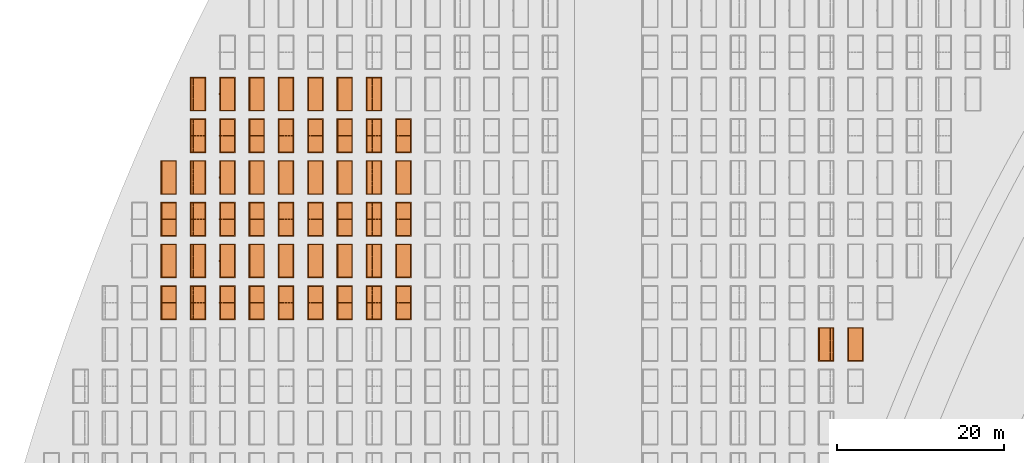
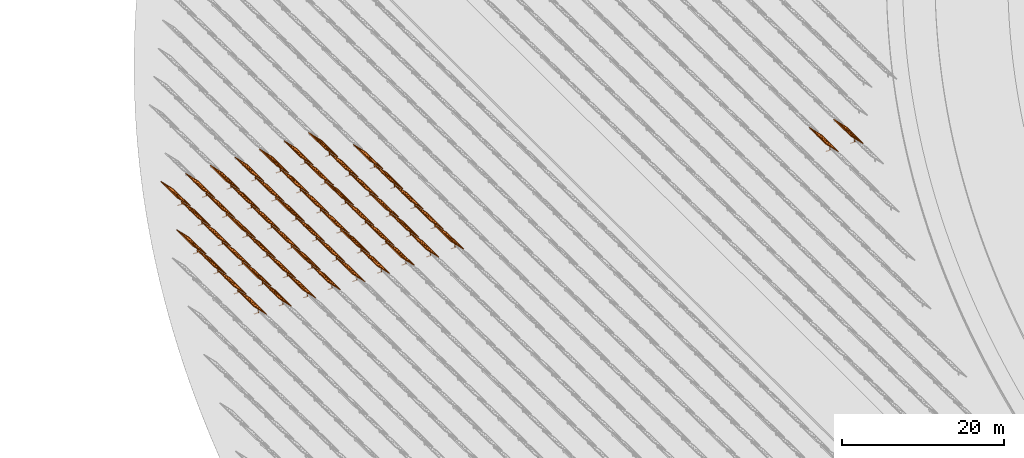
# One storey, part 27 of 39: 53 proxies.
"""IFC2X3 building model written with IfcOpenShell, lengths in millimetres."""

from ifc_helpers import new_model, entity, si_unit, converted_unit, derived_unit, direction, frame, frame_2d, origin, origin_2d_with_axis, place, context, subcontext, project, spatial, polyline, rectangle, outline, extrude, source, transform, mapped, material, material_list, element, save


model = new_model("IFC2X3")

# Units and contexts
model_context = context("Model", 3, precision=1e-06, world=origin(), true_north=direction((2.0, 6.12303176911189e-17, 1.0)))
context_of_model = context(None, 3, precision=1e-06, world=origin(), true_north=direction((2.0, 6.12303176911189e-17, 1.0)))
body_context = subcontext(model_context, "Body", "Model", "MODEL_VIEW")
ifc_project = project(units=[si_unit("LENGTHUNIT", "METRE", prefix="MILLI"), si_unit("AREAUNIT", "SQUARE_METRE", prefix="MILLI"), si_unit("VOLUMEUNIT", "CUBIC_METRE", prefix="MILLI"), converted_unit("PLANEANGLEUNIT", "DEGREE", entity("IfcRatioMeasure", 0.0174532925199433), si_unit("PLANEANGLEUNIT", "RADIAN"), dimensions=[0, 0, 0, 0, 0, 0, 0]), si_unit("MASSUNIT", "GRAM", prefix="KILO"), si_unit("TIMEUNIT", "SECOND"), si_unit("THERMODYNAMICTEMPERATUREUNIT", "KELVIN"), derived_unit("THERMALTRANSMITTANCEUNIT", [(si_unit("MASSUNIT", "GRAM", prefix="KILO"), 1), (si_unit("THERMODYNAMICTEMPERATUREUNIT", "KELVIN"), -1), (si_unit("TIMEUNIT", "SECOND"), -3)]), derived_unit("VOLUMETRICFLOWRATEUNIT", [(si_unit("LENGTHUNIT", "METRE"), 3), (si_unit("TIMEUNIT", "SECOND"), -1)])], contexts=[model_context, context_of_model])

# Site, building, storey
site_placement = place(None, origin())
site = spatial("IfcSite", under=ifc_project, at=site_placement, CompositionType="ELEMENT")
building_placement = place(site_placement, origin())
building = spatial("IfcBuilding", under=site, at=building_placement, CompositionType="ELEMENT")
storey_placement = place(building_placement, frame((0.0, 0.0, 4000.0)))
storey = spatial("IfcBuildingStorey", under=building, at=storey_placement, Name="Level 2", CompositionType="ELEMENT", Elevation=4000.0)

# Proxies
ifc_material_1 = material(Name="Stand-Steel")
ifc_material_2 = material(Name="Aluminium")
ifc_material_3 = material(Name="Glass")
ifc_material_list_1 = material_list([ifc_material_1, ifc_material_2, ifc_material_3])
shared_shape = source(origin(), body_context, "Body", "SweptSolid", [
    extrude(outline(polyline([(-629.526235435404, -220.0), (329.763117717702, -220.0), (329.763117717703, 410.0), (299.763117717703, 410.0), (299.763117717702, -190.0), (-629.526235435404, -190.0), (-629.526235435404, -220.0)])), frame((-190.00003127179, -100.0, 299.763117717707), z_axis=(0.0, 1.0, 0.0), x_axis=(0.0, 0.0, -1.0)), (0.0, 0.0, 1.0), 200.0),
    extrude(rectangle(XDim=20.0000000000001, YDim=200.0, at=frame_2d((0.0, -7.105427357601e-14), x_axis=(0.0, 1.0))), frame((-7.07109908365613, 0.0, 922.21828534124), z_axis=(-0.70710678118654, 0.0, 0.707106781186555), x_axis=(0.0, 1.0, 0.0)), (0.0, 0.0, 1.0), 2600.0),
    extrude(rectangle(XDim=24.9999999999997, YDim=24.9999999999999, at=frame_2d((2.87769807982841e-13, -9.50350909079134e-14), x_axis=(1.0, 0.0))), frame((-1449.56292018118, -1950.0, 2449.57494522722), z_axis=(0.0, 1.0, 0.0), x_axis=(-0.707106781186548, 0.0, -0.707106781186548)), (0.0, 0.0, 1.0), 3900.0),
    extrude(rectangle(XDim=24.9999999999999, YDim=25.0000000000001, at=origin_2d_with_axis()), frame((-1096.0095295879, -1950.0, 2096.02155463395), z_axis=(0.0, 1.0, 0.0), x_axis=(-0.707106781186542, 0.0, -0.707106781186553)), (0.0, 0.0, 1.0), 3900.0),
    extrude(rectangle(XDim=24.9999999999999, YDim=25.0000000000001, at=origin_2d_with_axis()), frame((-742.456138994631, -1950.0, 1742.46816404067), z_axis=(0.0, 1.0, 0.0), x_axis=(-0.707106781186542, 0.0, -0.707106781186553)), (0.0, 0.0, 1.0), 3900.0),
    extrude(rectangle(XDim=25.0, YDim=24.9999999999997, at=frame_2d((-7.19424519957101e-14, 1.19904086659517e-13), x_axis=(1.0, 0.0))), frame((-388.902748401358, -1950.0, 1388.9147734474), z_axis=(0.0, 1.0, 0.0), x_axis=(-0.707106781186545, 0.0, -0.70710678118655)), (0.0, 0.0, 1.0), 3900.0),
    extrude(rectangle(XDim=25.0000000000002, YDim=25.0, at=frame_2d((1.35891298214119e-13, 6.21724893790088e-15), x_axis=(0.0, 1.0))), frame((-35.3553703311048, 1500.0, 1035.35537033109), z_axis=(-0.707106781186544, 0.0, 0.707106781186551), x_axis=(0.0, 1.0, 0.0)), (0.0, 0.0, 1.0), 2440.0),
    extrude(rectangle(XDim=25.0000000000002, YDim=25.0, at=frame_2d((0.0, 1.77635683940025e-15), x_axis=(0.0, 1.0))), frame((-35.3553703311059, 1000.0, 1035.35537033109), z_axis=(-0.707106781186546, 0.0, 0.707106781186549), x_axis=(0.0, 1.0, 0.0)), (0.0, 0.0, 1.0), 2440.0),
    extrude(rectangle(XDim=25.0000000000002, YDim=25.0, at=frame_2d((0.0, 8.43769498715119e-14), x_axis=(0.0, 1.0))), frame((-26.5165355662756, 0.0, 1044.19420509593), z_axis=(-0.707106781186546, 0.0, 0.707106781186549), x_axis=(0.0, -1.0, 0.0)), (0.0, 0.0, 1.0), 2440.0),
    extrude(rectangle(XDim=25.0000000000002, YDim=25.0, at=frame_2d((0.0, 8.88178419700125e-16), x_axis=(0.0, 1.0))), frame((-35.3553703311065, 500.0, 1035.35537033109), z_axis=(-0.707106781186546, 0.0, 0.707106781186549), x_axis=(0.0, 1.0, 0.0)), (0.0, 0.0, 1.0), 2440.0),
    extrude(rectangle(XDim=25.0000000000002, YDim=25.0, at=frame_2d((0.0, 8.88178419700125e-16), x_axis=(0.0, 1.0))), frame((-35.3553703311086, -500.0, 1035.35537033109), z_axis=(-0.707106781186546, 0.0, 0.707106781186549), x_axis=(0.0, 1.0, 0.0)), (0.0, 0.0, 1.0), 2440.0),
    extrude(rectangle(XDim=25.0000000000002, YDim=25.0, at=frame_2d((0.0, 8.88178419700125e-16), x_axis=(0.0, 1.0))), frame((-35.3553703311095, -1000.0, 1035.35537033109), z_axis=(-0.707106781186546, 0.0, 0.707106781186549), x_axis=(0.0, 1.0, 0.0)), (0.0, 0.0, 1.0), 2440.0),
    extrude(rectangle(XDim=25.0000000000002, YDim=25.0, at=frame_2d((1.35891298214119e-13, 1.77635683940025e-15), x_axis=(0.0, 1.0))), frame((-35.3553703311107, -1500.0, 1035.35537033109), z_axis=(-0.707106781186546, 0.0, 0.707106781186549), x_axis=(0.0, 1.0, 0.0)), (0.0, 0.0, 1.0), 2440.0),
    extrude(rectangle(XDim=2400.0, YDim=11.9999999999994, at=frame_2d((-1.13686837721616e-13, 2.02948768901479e-13), x_axis=(1.0, 0.0))), frame((-883.883507754966, -1950.0, 1883.88350775495), z_axis=(0.0, 1.0, 0.0), x_axis=(0.707106781186546, 0.0, -0.707106781186549)), (0.0, 0.0, 1.0), 3900.0),
    extrude(outline(polyline([(-2050.0, -1300.0), (2050.0, -1300.0), (2050.0, 1300.0), (-2050.0, 1300.0), (-2050.0, -1300.0)]), holes=[polyline([(1950.0, -1200.0), (-1950.0, -1200.0), (-1950.0, 1200.0), (1950.0, 1200.0), (1950.0, -1200.0)])]), frame((-919.238846814293, 0.0, 1848.52816869563), z_axis=(0.707106781186554, 0.0, 0.707106781186541), x_axis=(0.0, 1.0, 0.0)), (0.0, 0.0, 1.0), 99.9999999999898),
])
proxy_1_placement = place(storey_placement, frame((-126810.276453181, 560144.680552408, 30.0)))
element("IfcBuildingElementProxy", 1, at=proxy_1_placement, inside=storey, material=ifc_material_list_1, Name="Solar Panel_4000X2500:Solar Panel_4000X2500", ObjectType="Solar Panel_4000X2500", CompositionType="ELEMENT", context=body_context, shape_type="MappedRepresentation", body=[
    mapped(shared_shape, transform((0.0, 0.0, 0.0), scale=1.0)),
])
ifc_material_list_2 = material_list([ifc_material_1, ifc_material_2, ifc_material_3])
proxy_2_placement = place(storey_placement, frame((-123295.266081452, 560144.680552408, 30.0)))
element("IfcBuildingElementProxy", 2, at=proxy_2_placement, inside=storey, material=ifc_material_list_2, Name="Solar Panel_4000X2500:Solar Panel_4000X2500", ObjectType="Solar Panel_4000X2500", CompositionType="ELEMENT", context=body_context, shape_type="MappedRepresentation", body=[
    mapped(shared_shape, transform((0.0, 0.0, 0.0), scale=1.0)),
])
ifc_material_list_3 = material_list([ifc_material_1, ifc_material_2, ifc_material_3])
proxy_3_placement = place(storey_placement, frame((-177460.32831183, 565144.680552408, 30.0)))
element("IfcBuildingElementProxy", 3, at=proxy_3_placement, inside=storey, material=ifc_material_list_3, Name="Solar Panel_4000X2500:Solar Panel_4000X2500", ObjectType="Solar Panel_4000X2500", CompositionType="ELEMENT", context=body_context, shape_type="MappedRepresentation", body=[
    mapped(shared_shape, transform((0.0, 0.0, 0.0), scale=1.0)),
])
ifc_material_list_4 = material_list([ifc_material_1, ifc_material_2, ifc_material_3])
proxy_4_placement = place(storey_placement, frame((-177460.32831183, 570144.680552408, 30.0)))
element("IfcBuildingElementProxy", 4, at=proxy_4_placement, inside=storey, material=ifc_material_list_4, Name="Solar Panel_4000X2500:Solar Panel_4000X2500", ObjectType="Solar Panel_4000X2500", CompositionType="ELEMENT", context=body_context, shape_type="MappedRepresentation", body=[
    mapped(shared_shape, transform((0.0, 0.0, 0.0), scale=1.0)),
])
ifc_material_list_5 = material_list([ifc_material_1, ifc_material_2, ifc_material_3])
proxy_5_placement = place(storey_placement, frame((-177460.32831183, 575144.680552408, 30.0)))
element("IfcBuildingElementProxy", 5, at=proxy_5_placement, inside=storey, material=ifc_material_list_5, Name="Solar Panel_4000X2500:Solar Panel_4000X2500", ObjectType="Solar Panel_4000X2500", CompositionType="ELEMENT", context=body_context, shape_type="MappedRepresentation", body=[
    mapped(shared_shape, transform((0.0, 0.0, 0.0), scale=1.0)),
])
ifc_material_list_6 = material_list([ifc_material_1, ifc_material_2, ifc_material_3])
proxy_6_placement = place(storey_placement, frame((-177460.32831183, 580144.680552408, 30.0)))
element("IfcBuildingElementProxy", 6, at=proxy_6_placement, inside=storey, material=ifc_material_list_6, Name="Solar Panel_4000X2500:Solar Panel_4000X2500", ObjectType="Solar Panel_4000X2500", CompositionType="ELEMENT", context=body_context, shape_type="MappedRepresentation", body=[
    mapped(shared_shape, transform((0.0, 0.0, 0.0), scale=1.0)),
])
ifc_material_list_7 = material_list([ifc_material_1, ifc_material_2, ifc_material_3])
proxy_7_placement = place(storey_placement, frame((-177460.32831183, 585144.680552408, 30.0)))
element("IfcBuildingElementProxy", 7, at=proxy_7_placement, inside=storey, material=ifc_material_list_7, Name="Solar Panel_4000X2500:Solar Panel_4000X2500", ObjectType="Solar Panel_4000X2500", CompositionType="ELEMENT", context=body_context, shape_type="MappedRepresentation", body=[
    mapped(shared_shape, transform((0.0, 0.0, 0.0), scale=1.0)),
])
ifc_material_list_8 = material_list([ifc_material_1, ifc_material_2, ifc_material_3])
proxy_8_placement = place(storey_placement, frame((-180975.32831183, 565144.680552408, 30.0)))
element("IfcBuildingElementProxy", 8, at=proxy_8_placement, inside=storey, material=ifc_material_list_8, Name="Solar Panel_4000X2500:Solar Panel_4000X2500", ObjectType="Solar Panel_4000X2500", CompositionType="ELEMENT", context=body_context, shape_type="MappedRepresentation", body=[
    mapped(shared_shape, transform((0.0, 0.0, 0.0), scale=1.0)),
])
ifc_material_list_9 = material_list([ifc_material_1, ifc_material_2, ifc_material_3])
proxy_9_placement = place(storey_placement, frame((-180975.32831183, 570144.680552408, 30.0)))
element("IfcBuildingElementProxy", 9, at=proxy_9_placement, inside=storey, material=ifc_material_list_9, Name="Solar Panel_4000X2500:Solar Panel_4000X2500", ObjectType="Solar Panel_4000X2500", CompositionType="ELEMENT", context=body_context, shape_type="MappedRepresentation", body=[
    mapped(shared_shape, transform((0.0, 0.0, 0.0), scale=1.0)),
])
ifc_material_list_10 = material_list([ifc_material_1, ifc_material_2, ifc_material_3])
proxy_10_placement = place(storey_placement, frame((-180975.32831183, 575144.680552408, 30.0)))
element("IfcBuildingElementProxy", 10, at=proxy_10_placement, inside=storey, material=ifc_material_list_10, Name="Solar Panel_4000X2500:Solar Panel_4000X2500", ObjectType="Solar Panel_4000X2500", CompositionType="ELEMENT", context=body_context, shape_type="MappedRepresentation", body=[
    mapped(shared_shape, transform((0.0, 0.0, 0.0), scale=1.0)),
])
ifc_material_list_11 = material_list([ifc_material_1, ifc_material_2, ifc_material_3])
proxy_11_placement = place(storey_placement, frame((-180975.32831183, 580144.680552408, 30.0)))
element("IfcBuildingElementProxy", 11, at=proxy_11_placement, inside=storey, material=ifc_material_list_11, Name="Solar Panel_4000X2500:Solar Panel_4000X2500", ObjectType="Solar Panel_4000X2500", CompositionType="ELEMENT", context=body_context, shape_type="MappedRepresentation", body=[
    mapped(shared_shape, transform((0.0, 0.0, 0.0), scale=1.0)),
])
ifc_material_list_12 = material_list([ifc_material_1, ifc_material_2, ifc_material_3])
proxy_12_placement = place(storey_placement, frame((-180975.32831183, 585144.680552408, 30.0)))
element("IfcBuildingElementProxy", 12, at=proxy_12_placement, inside=storey, material=ifc_material_list_12, Name="Solar Panel_4000X2500:Solar Panel_4000X2500", ObjectType="Solar Panel_4000X2500", CompositionType="ELEMENT", context=body_context, shape_type="MappedRepresentation", body=[
    mapped(shared_shape, transform((0.0, 0.0, 0.0), scale=1.0)),
])
ifc_material_list_13 = material_list([ifc_material_1, ifc_material_2, ifc_material_3])
proxy_13_placement = place(storey_placement, frame((-180975.32831183, 590144.680552408, 30.0)))
element("IfcBuildingElementProxy", 13, at=proxy_13_placement, inside=storey, material=ifc_material_list_13, Name="Solar Panel_4000X2500:Solar Panel_4000X2500", ObjectType="Solar Panel_4000X2500", CompositionType="ELEMENT", context=body_context, shape_type="MappedRepresentation", body=[
    mapped(shared_shape, transform((0.0, 0.0, 0.0), scale=1.0)),
])
ifc_material_list_14 = material_list([ifc_material_1, ifc_material_2, ifc_material_3])
proxy_14_placement = place(storey_placement, frame((-184490.32831183, 565144.680552408, 30.0)))
element("IfcBuildingElementProxy", 14, at=proxy_14_placement, inside=storey, material=ifc_material_list_14, Name="Solar Panel_4000X2500:Solar Panel_4000X2500", ObjectType="Solar Panel_4000X2500", CompositionType="ELEMENT", context=body_context, shape_type="MappedRepresentation", body=[
    mapped(shared_shape, transform((0.0, 0.0, 0.0), scale=1.0)),
])
ifc_material_list_15 = material_list([ifc_material_1, ifc_material_2, ifc_material_3])
proxy_15_placement = place(storey_placement, frame((-184490.32831183, 570144.680552408, 30.0)))
element("IfcBuildingElementProxy", 15, at=proxy_15_placement, inside=storey, material=ifc_material_list_15, Name="Solar Panel_4000X2500:Solar Panel_4000X2500", ObjectType="Solar Panel_4000X2500", CompositionType="ELEMENT", context=body_context, shape_type="MappedRepresentation", body=[
    mapped(shared_shape, transform((0.0, 0.0, 0.0), scale=1.0)),
])
ifc_material_list_16 = material_list([ifc_material_1, ifc_material_2, ifc_material_3])
proxy_16_placement = place(storey_placement, frame((-184490.32831183, 575144.680552408, 30.0)))
element("IfcBuildingElementProxy", 16, at=proxy_16_placement, inside=storey, material=ifc_material_list_16, Name="Solar Panel_4000X2500:Solar Panel_4000X2500", ObjectType="Solar Panel_4000X2500", CompositionType="ELEMENT", context=body_context, shape_type="MappedRepresentation", body=[
    mapped(shared_shape, transform((0.0, 0.0, 0.0), scale=1.0)),
])
ifc_material_list_17 = material_list([ifc_material_1, ifc_material_2, ifc_material_3])
proxy_17_placement = place(storey_placement, frame((-184490.32831183, 580144.680552408, 30.0)))
element("IfcBuildingElementProxy", 17, at=proxy_17_placement, inside=storey, material=ifc_material_list_17, Name="Solar Panel_4000X2500:Solar Panel_4000X2500", ObjectType="Solar Panel_4000X2500", CompositionType="ELEMENT", context=body_context, shape_type="MappedRepresentation", body=[
    mapped(shared_shape, transform((0.0, 0.0, 0.0), scale=1.0)),
])
ifc_material_list_18 = material_list([ifc_material_1, ifc_material_2, ifc_material_3])
proxy_18_placement = place(storey_placement, frame((-184490.32831183, 585144.680552408, 30.0)))
element("IfcBuildingElementProxy", 18, at=proxy_18_placement, inside=storey, material=ifc_material_list_18, Name="Solar Panel_4000X2500:Solar Panel_4000X2500", ObjectType="Solar Panel_4000X2500", CompositionType="ELEMENT", context=body_context, shape_type="MappedRepresentation", body=[
    mapped(shared_shape, transform((0.0, 0.0, 0.0), scale=1.0)),
])
ifc_material_list_19 = material_list([ifc_material_1, ifc_material_2, ifc_material_3])
proxy_19_placement = place(storey_placement, frame((-184490.32831183, 590144.680552408, 30.0)))
element("IfcBuildingElementProxy", 19, at=proxy_19_placement, inside=storey, material=ifc_material_list_19, Name="Solar Panel_4000X2500:Solar Panel_4000X2500", ObjectType="Solar Panel_4000X2500", CompositionType="ELEMENT", context=body_context, shape_type="MappedRepresentation", body=[
    mapped(shared_shape, transform((0.0, 0.0, 0.0), scale=1.0)),
])
ifc_material_list_20 = material_list([ifc_material_1, ifc_material_2, ifc_material_3])
proxy_20_placement = place(storey_placement, frame((-188005.32831183, 565144.680552408, 30.0)))
element("IfcBuildingElementProxy", 20, at=proxy_20_placement, inside=storey, material=ifc_material_list_20, Name="Solar Panel_4000X2500:Solar Panel_4000X2500", ObjectType="Solar Panel_4000X2500", CompositionType="ELEMENT", context=body_context, shape_type="MappedRepresentation", body=[
    mapped(shared_shape, transform((0.0, 0.0, 0.0), scale=1.0)),
])
ifc_material_list_21 = material_list([ifc_material_1, ifc_material_2, ifc_material_3])
proxy_21_placement = place(storey_placement, frame((-188005.32831183, 570144.680552408, 30.0)))
element("IfcBuildingElementProxy", 21, at=proxy_21_placement, inside=storey, material=ifc_material_list_21, Name="Solar Panel_4000X2500:Solar Panel_4000X2500", ObjectType="Solar Panel_4000X2500", CompositionType="ELEMENT", context=body_context, shape_type="MappedRepresentation", body=[
    mapped(shared_shape, transform((0.0, 0.0, 0.0), scale=1.0)),
])
ifc_material_list_22 = material_list([ifc_material_1, ifc_material_2, ifc_material_3])
proxy_22_placement = place(storey_placement, frame((-188005.32831183, 575144.680552408, 30.0)))
element("IfcBuildingElementProxy", 22, at=proxy_22_placement, inside=storey, material=ifc_material_list_22, Name="Solar Panel_4000X2500:Solar Panel_4000X2500", ObjectType="Solar Panel_4000X2500", CompositionType="ELEMENT", context=body_context, shape_type="MappedRepresentation", body=[
    mapped(shared_shape, transform((0.0, 0.0, 0.0), scale=1.0)),
])
ifc_material_list_23 = material_list([ifc_material_1, ifc_material_2, ifc_material_3])
proxy_23_placement = place(storey_placement, frame((-188005.32831183, 580144.680552408, 30.0)))
element("IfcBuildingElementProxy", 23, at=proxy_23_placement, inside=storey, material=ifc_material_list_23, Name="Solar Panel_4000X2500:Solar Panel_4000X2500", ObjectType="Solar Panel_4000X2500", CompositionType="ELEMENT", context=body_context, shape_type="MappedRepresentation", body=[
    mapped(shared_shape, transform((0.0, 0.0, 0.0), scale=1.0)),
])
ifc_material_list_24 = material_list([ifc_material_1, ifc_material_2, ifc_material_3])
proxy_24_placement = place(storey_placement, frame((-188005.32831183, 585144.680552408, 30.0)))
element("IfcBuildingElementProxy", 24, at=proxy_24_placement, inside=storey, material=ifc_material_list_24, Name="Solar Panel_4000X2500:Solar Panel_4000X2500", ObjectType="Solar Panel_4000X2500", CompositionType="ELEMENT", context=body_context, shape_type="MappedRepresentation", body=[
    mapped(shared_shape, transform((0.0, 0.0, 0.0), scale=1.0)),
])
ifc_material_list_25 = material_list([ifc_material_1, ifc_material_2, ifc_material_3])
proxy_25_placement = place(storey_placement, frame((-188005.32831183, 590144.680552408, 30.0)))
element("IfcBuildingElementProxy", 25, at=proxy_25_placement, inside=storey, material=ifc_material_list_25, Name="Solar Panel_4000X2500:Solar Panel_4000X2500", ObjectType="Solar Panel_4000X2500", CompositionType="ELEMENT", context=body_context, shape_type="MappedRepresentation", body=[
    mapped(shared_shape, transform((0.0, 0.0, 0.0), scale=1.0)),
])
ifc_material_list_26 = material_list([ifc_material_1, ifc_material_2, ifc_material_3])
proxy_26_placement = place(storey_placement, frame((-191520.32831183, 565144.680552408, 30.0)))
element("IfcBuildingElementProxy", 26, at=proxy_26_placement, inside=storey, material=ifc_material_list_26, Name="Solar Panel_4000X2500:Solar Panel_4000X2500", ObjectType="Solar Panel_4000X2500", CompositionType="ELEMENT", context=body_context, shape_type="MappedRepresentation", body=[
    mapped(shared_shape, transform((0.0, 0.0, 0.0), scale=1.0)),
])
ifc_material_list_27 = material_list([ifc_material_1, ifc_material_2, ifc_material_3])
proxy_27_placement = place(storey_placement, frame((-191520.32831183, 570144.680552408, 30.0)))
element("IfcBuildingElementProxy", 27, at=proxy_27_placement, inside=storey, material=ifc_material_list_27, Name="Solar Panel_4000X2500:Solar Panel_4000X2500", ObjectType="Solar Panel_4000X2500", CompositionType="ELEMENT", context=body_context, shape_type="MappedRepresentation", body=[
    mapped(shared_shape, transform((0.0, 0.0, 0.0), scale=1.0)),
])
ifc_material_list_28 = material_list([ifc_material_1, ifc_material_2, ifc_material_3])
proxy_28_placement = place(storey_placement, frame((-191520.32831183, 575144.680552408, 30.0)))
element("IfcBuildingElementProxy", 28, at=proxy_28_placement, inside=storey, material=ifc_material_list_28, Name="Solar Panel_4000X2500:Solar Panel_4000X2500", ObjectType="Solar Panel_4000X2500", CompositionType="ELEMENT", context=body_context, shape_type="MappedRepresentation", body=[
    mapped(shared_shape, transform((0.0, 0.0, 0.0), scale=1.0)),
])
ifc_material_list_29 = material_list([ifc_material_1, ifc_material_2, ifc_material_3])
proxy_29_placement = place(storey_placement, frame((-191520.32831183, 580144.680552408, 30.0)))
element("IfcBuildingElementProxy", 29, at=proxy_29_placement, inside=storey, material=ifc_material_list_29, Name="Solar Panel_4000X2500:Solar Panel_4000X2500", ObjectType="Solar Panel_4000X2500", CompositionType="ELEMENT", context=body_context, shape_type="MappedRepresentation", body=[
    mapped(shared_shape, transform((0.0, 0.0, 0.0), scale=1.0)),
])
ifc_material_list_30 = material_list([ifc_material_1, ifc_material_2, ifc_material_3])
proxy_30_placement = place(storey_placement, frame((-191520.32831183, 585144.680552408, 30.0)))
element("IfcBuildingElementProxy", 30, at=proxy_30_placement, inside=storey, material=ifc_material_list_30, Name="Solar Panel_4000X2500:Solar Panel_4000X2500", ObjectType="Solar Panel_4000X2500", CompositionType="ELEMENT", context=body_context, shape_type="MappedRepresentation", body=[
    mapped(shared_shape, transform((0.0, 0.0, 0.0), scale=1.0)),
])
ifc_material_list_31 = material_list([ifc_material_1, ifc_material_2, ifc_material_3])
proxy_31_placement = place(storey_placement, frame((-191520.32831183, 590144.680552408, 30.0)))
element("IfcBuildingElementProxy", 31, at=proxy_31_placement, inside=storey, material=ifc_material_list_31, Name="Solar Panel_4000X2500:Solar Panel_4000X2500", ObjectType="Solar Panel_4000X2500", CompositionType="ELEMENT", context=body_context, shape_type="MappedRepresentation", body=[
    mapped(shared_shape, transform((0.0, 0.0, 0.0), scale=1.0)),
])
ifc_material_list_32 = material_list([ifc_material_1, ifc_material_2, ifc_material_3])
proxy_32_placement = place(storey_placement, frame((-195035.32831183, 565144.680552408, 30.0)))
element("IfcBuildingElementProxy", 32, at=proxy_32_placement, inside=storey, material=ifc_material_list_32, Name="Solar Panel_4000X2500:Solar Panel_4000X2500", ObjectType="Solar Panel_4000X2500", CompositionType="ELEMENT", context=body_context, shape_type="MappedRepresentation", body=[
    mapped(shared_shape, transform((0.0, 0.0, 0.0), scale=1.0)),
])
ifc_material_list_33 = material_list([ifc_material_1, ifc_material_2, ifc_material_3])
proxy_33_placement = place(storey_placement, frame((-195035.32831183, 570144.680552408, 30.0)))
element("IfcBuildingElementProxy", 33, at=proxy_33_placement, inside=storey, material=ifc_material_list_33, Name="Solar Panel_4000X2500:Solar Panel_4000X2500", ObjectType="Solar Panel_4000X2500", CompositionType="ELEMENT", context=body_context, shape_type="MappedRepresentation", body=[
    mapped(shared_shape, transform((0.0, 0.0, 0.0), scale=1.0)),
])
ifc_material_list_34 = material_list([ifc_material_1, ifc_material_2, ifc_material_3])
proxy_34_placement = place(storey_placement, frame((-195035.32831183, 575144.680552408, 30.0)))
element("IfcBuildingElementProxy", 34, at=proxy_34_placement, inside=storey, material=ifc_material_list_34, Name="Solar Panel_4000X2500:Solar Panel_4000X2500", ObjectType="Solar Panel_4000X2500", CompositionType="ELEMENT", context=body_context, shape_type="MappedRepresentation", body=[
    mapped(shared_shape, transform((0.0, 0.0, 0.0), scale=1.0)),
])
ifc_material_list_35 = material_list([ifc_material_1, ifc_material_2, ifc_material_3])
proxy_35_placement = place(storey_placement, frame((-195035.32831183, 580144.680552408, 30.0)))
element("IfcBuildingElementProxy", 35, at=proxy_35_placement, inside=storey, material=ifc_material_list_35, Name="Solar Panel_4000X2500:Solar Panel_4000X2500", ObjectType="Solar Panel_4000X2500", CompositionType="ELEMENT", context=body_context, shape_type="MappedRepresentation", body=[
    mapped(shared_shape, transform((0.0, 0.0, 0.0), scale=1.0)),
])
ifc_material_list_36 = material_list([ifc_material_1, ifc_material_2, ifc_material_3])
proxy_36_placement = place(storey_placement, frame((-195035.32831183, 585144.680552408, 30.0)))
element("IfcBuildingElementProxy", 36, at=proxy_36_placement, inside=storey, material=ifc_material_list_36, Name="Solar Panel_4000X2500:Solar Panel_4000X2500", ObjectType="Solar Panel_4000X2500", CompositionType="ELEMENT", context=body_context, shape_type="MappedRepresentation", body=[
    mapped(shared_shape, transform((0.0, 0.0, 0.0), scale=1.0)),
])
ifc_material_list_37 = material_list([ifc_material_1, ifc_material_2, ifc_material_3])
proxy_37_placement = place(storey_placement, frame((-195035.32831183, 590144.680552408, 30.0)))
element("IfcBuildingElementProxy", 37, at=proxy_37_placement, inside=storey, material=ifc_material_list_37, Name="Solar Panel_4000X2500:Solar Panel_4000X2500", ObjectType="Solar Panel_4000X2500", CompositionType="ELEMENT", context=body_context, shape_type="MappedRepresentation", body=[
    mapped(shared_shape, transform((0.0, 0.0, 0.0), scale=1.0)),
])
ifc_material_list_38 = material_list([ifc_material_1, ifc_material_2, ifc_material_3])
proxy_38_placement = place(storey_placement, frame((-198550.32831183, 565144.680552408, 30.0)))
element("IfcBuildingElementProxy", 38, at=proxy_38_placement, inside=storey, material=ifc_material_list_38, Name="Solar Panel_4000X2500:Solar Panel_4000X2500", ObjectType="Solar Panel_4000X2500", CompositionType="ELEMENT", context=body_context, shape_type="MappedRepresentation", body=[
    mapped(shared_shape, transform((0.0, 0.0, 0.0), scale=1.0)),
])
ifc_material_list_39 = material_list([ifc_material_1, ifc_material_2, ifc_material_3])
proxy_39_placement = place(storey_placement, frame((-198550.32831183, 570144.680552408, 30.0)))
element("IfcBuildingElementProxy", 39, at=proxy_39_placement, inside=storey, material=ifc_material_list_39, Name="Solar Panel_4000X2500:Solar Panel_4000X2500", ObjectType="Solar Panel_4000X2500", CompositionType="ELEMENT", context=body_context, shape_type="MappedRepresentation", body=[
    mapped(shared_shape, transform((0.0, 0.0, 0.0), scale=1.0)),
])
ifc_material_list_40 = material_list([ifc_material_1, ifc_material_2, ifc_material_3])
proxy_40_placement = place(storey_placement, frame((-198550.32831183, 575144.680552408, 30.0)))
element("IfcBuildingElementProxy", 40, at=proxy_40_placement, inside=storey, material=ifc_material_list_40, Name="Solar Panel_4000X2500:Solar Panel_4000X2500", ObjectType="Solar Panel_4000X2500", CompositionType="ELEMENT", context=body_context, shape_type="MappedRepresentation", body=[
    mapped(shared_shape, transform((0.0, 0.0, 0.0), scale=1.0)),
])
ifc_material_list_41 = material_list([ifc_material_1, ifc_material_2, ifc_material_3])
proxy_41_placement = place(storey_placement, frame((-198550.32831183, 580144.680552408, 30.0)))
element("IfcBuildingElementProxy", 41, at=proxy_41_placement, inside=storey, material=ifc_material_list_41, Name="Solar Panel_4000X2500:Solar Panel_4000X2500", ObjectType="Solar Panel_4000X2500", CompositionType="ELEMENT", context=body_context, shape_type="MappedRepresentation", body=[
    mapped(shared_shape, transform((0.0, 0.0, 0.0), scale=1.0)),
])
ifc_material_list_42 = material_list([ifc_material_1, ifc_material_2, ifc_material_3])
proxy_42_placement = place(storey_placement, frame((-198550.32831183, 585144.680552408, 30.0)))
element("IfcBuildingElementProxy", 42, at=proxy_42_placement, inside=storey, material=ifc_material_list_42, Name="Solar Panel_4000X2500:Solar Panel_4000X2500", ObjectType="Solar Panel_4000X2500", CompositionType="ELEMENT", context=body_context, shape_type="MappedRepresentation", body=[
    mapped(shared_shape, transform((0.0, 0.0, 0.0), scale=1.0)),
])
ifc_material_list_43 = material_list([ifc_material_1, ifc_material_2, ifc_material_3])
proxy_43_placement = place(storey_placement, frame((-198550.32831183, 590144.680552408, 30.0)))
element("IfcBuildingElementProxy", 43, at=proxy_43_placement, inside=storey, material=ifc_material_list_43, Name="Solar Panel_4000X2500:Solar Panel_4000X2500", ObjectType="Solar Panel_4000X2500", CompositionType="ELEMENT", context=body_context, shape_type="MappedRepresentation", body=[
    mapped(shared_shape, transform((0.0, 0.0, 0.0), scale=1.0)),
])
ifc_material_list_44 = material_list([ifc_material_1, ifc_material_2, ifc_material_3])
proxy_44_placement = place(storey_placement, frame((-202065.32831183, 565144.680552408, 30.0)))
element("IfcBuildingElementProxy", 44, at=proxy_44_placement, inside=storey, material=ifc_material_list_44, Name="Solar Panel_4000X2500:Solar Panel_4000X2500", ObjectType="Solar Panel_4000X2500", CompositionType="ELEMENT", context=body_context, shape_type="MappedRepresentation", body=[
    mapped(shared_shape, transform((0.0, 0.0, 0.0), scale=1.0)),
])
ifc_material_list_45 = material_list([ifc_material_1, ifc_material_2, ifc_material_3])
proxy_45_placement = place(storey_placement, frame((-202065.32831183, 570144.680552408, 30.0)))
element("IfcBuildingElementProxy", 45, at=proxy_45_placement, inside=storey, material=ifc_material_list_45, Name="Solar Panel_4000X2500:Solar Panel_4000X2500", ObjectType="Solar Panel_4000X2500", CompositionType="ELEMENT", context=body_context, shape_type="MappedRepresentation", body=[
    mapped(shared_shape, transform((0.0, 0.0, 0.0), scale=1.0)),
])
ifc_material_list_46 = material_list([ifc_material_1, ifc_material_2, ifc_material_3])
proxy_46_placement = place(storey_placement, frame((-202065.32831183, 575144.680552408, 30.0)))
element("IfcBuildingElementProxy", 46, at=proxy_46_placement, inside=storey, material=ifc_material_list_46, Name="Solar Panel_4000X2500:Solar Panel_4000X2500", ObjectType="Solar Panel_4000X2500", CompositionType="ELEMENT", context=body_context, shape_type="MappedRepresentation", body=[
    mapped(shared_shape, transform((0.0, 0.0, 0.0), scale=1.0)),
])
ifc_material_list_47 = material_list([ifc_material_1, ifc_material_2, ifc_material_3])
proxy_47_placement = place(storey_placement, frame((-202065.32831183, 580144.680552408, 30.0)))
element("IfcBuildingElementProxy", 47, at=proxy_47_placement, inside=storey, material=ifc_material_list_47, Name="Solar Panel_4000X2500:Solar Panel_4000X2500", ObjectType="Solar Panel_4000X2500", CompositionType="ELEMENT", context=body_context, shape_type="MappedRepresentation", body=[
    mapped(shared_shape, transform((0.0, 0.0, 0.0), scale=1.0)),
])
ifc_material_list_48 = material_list([ifc_material_1, ifc_material_2, ifc_material_3])
proxy_48_placement = place(storey_placement, frame((-205580.32831183, 565144.680552408, 30.0)))
element("IfcBuildingElementProxy", 48, at=proxy_48_placement, inside=storey, material=ifc_material_list_48, Name="Solar Panel_4000X2500:Solar Panel_4000X2500", ObjectType="Solar Panel_4000X2500", CompositionType="ELEMENT", context=body_context, shape_type="MappedRepresentation", body=[
    mapped(shared_shape, transform((0.0, 0.0, 0.0), scale=1.0)),
])
ifc_material_list_49 = material_list([ifc_material_1, ifc_material_2, ifc_material_3])
proxy_49_placement = place(storey_placement, frame((-205580.32831183, 570144.680552408, 30.0)))
element("IfcBuildingElementProxy", 49, at=proxy_49_placement, inside=storey, material=ifc_material_list_49, Name="Solar Panel_4000X2500:Solar Panel_4000X2500", ObjectType="Solar Panel_4000X2500", CompositionType="ELEMENT", context=body_context, shape_type="MappedRepresentation", body=[
    mapped(shared_shape, transform((0.0, 0.0, 0.0), scale=1.0)),
])
ifc_material_list_50 = material_list([ifc_material_1, ifc_material_2, ifc_material_3])
proxy_50_placement = place(storey_placement, frame((-205580.32831183, 575144.680552408, 30.0)))
element("IfcBuildingElementProxy", 50, at=proxy_50_placement, inside=storey, material=ifc_material_list_50, Name="Solar Panel_4000X2500:Solar Panel_4000X2500", ObjectType="Solar Panel_4000X2500", CompositionType="ELEMENT", context=body_context, shape_type="MappedRepresentation", body=[
    mapped(shared_shape, transform((0.0, 0.0, 0.0), scale=1.0)),
])
ifc_material_list_51 = material_list([ifc_material_1, ifc_material_2, ifc_material_3])
proxy_51_placement = place(storey_placement, frame((-202065.32831183, 585144.680552408, 30.0)))
element("IfcBuildingElementProxy", 51, at=proxy_51_placement, inside=storey, material=ifc_material_list_51, Name="Solar Panel_4000X2500:Solar Panel_4000X2500", ObjectType="Solar Panel_4000X2500", CompositionType="ELEMENT", context=body_context, shape_type="MappedRepresentation", body=[
    mapped(shared_shape, transform((0.0, 0.0, 0.0), scale=1.0)),
])
ifc_material_list_52 = material_list([ifc_material_1, ifc_material_2, ifc_material_3])
proxy_52_placement = place(storey_placement, frame((-205580.32831183, 580144.680552408, 30.0)))
element("IfcBuildingElementProxy", 52, at=proxy_52_placement, inside=storey, material=ifc_material_list_52, Name="Solar Panel_4000X2500:Solar Panel_4000X2500", ObjectType="Solar Panel_4000X2500", CompositionType="ELEMENT", context=body_context, shape_type="MappedRepresentation", body=[
    mapped(shared_shape, transform((0.0, 0.0, 0.0), scale=1.0)),
])
ifc_material_list_53 = material_list([ifc_material_1, ifc_material_2, ifc_material_3])
proxy_53_placement = place(storey_placement, frame((-202065.32831183, 590144.680552408, 30.0)))
element("IfcBuildingElementProxy", 53, at=proxy_53_placement, inside=storey, material=ifc_material_list_53, Name="Solar Panel_4000X2500:Solar Panel_4000X2500", ObjectType="Solar Panel_4000X2500", CompositionType="ELEMENT", context=body_context, shape_type="MappedRepresentation", body=[
    mapped(shared_shape, transform((0.0, 0.0, 0.0), scale=1.0)),
])

save(model, "model.ifc")
